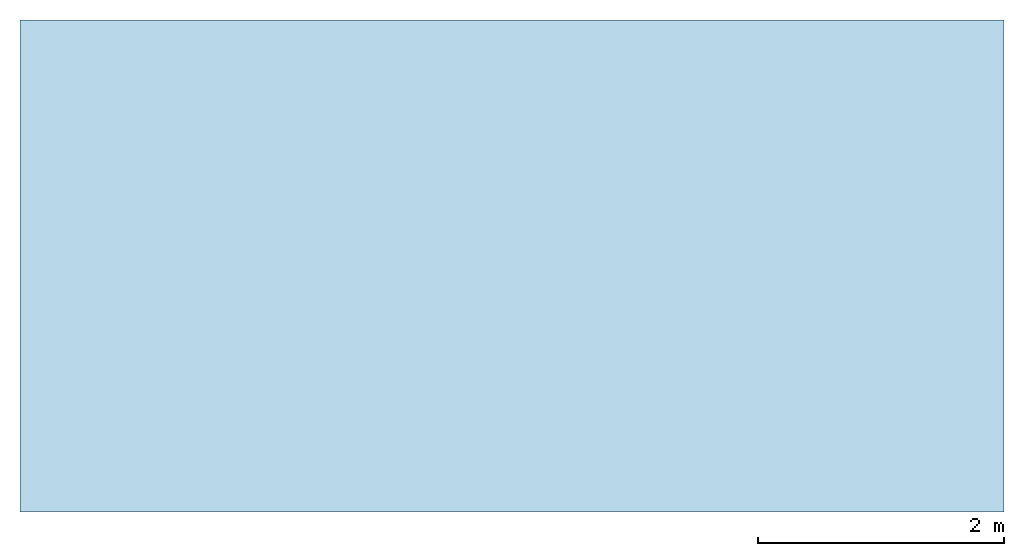
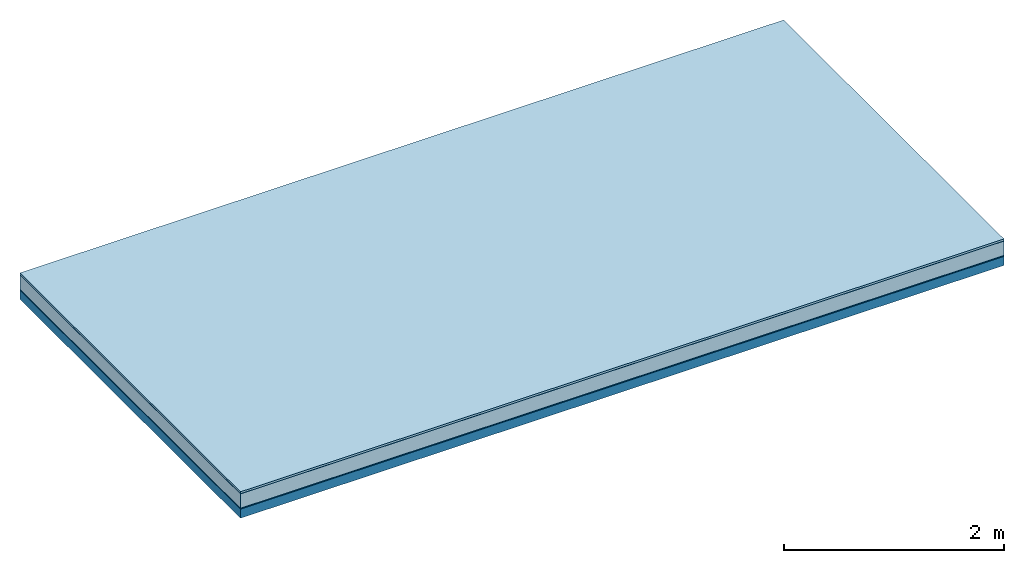
# One storey: 5 plates, 1 member, 1 element without a shape of its own.
"""IFC4 building model written with IfcOpenShell, lengths in metres."""

import ifcopenshell
import ifcopenshell.guid

model = None  # the IFC model being written
_history = None  # IfcOwnerHistory: only IFC2X3 demands one
_inside = {}  # id of a spatial element -> (the spatial element, [elements in it])
_under = {}  # id of a project, library or spatial element -> (it, [spatial elements below it])
_declared = {}  # id of a project -> (the project, [libraries it declares])
_typed = {}  # id of a type object -> (the type object, [elements of that type])
_made_of = {}  # id of a material, layer set ... -> (it, [elements and type objects made of it])


def new_model(schema):
    """Start an empty IFC model of exactly this schema.

    Asked for "IFC4X3", IfcOpenShell would pick the latest addendum, in which some entities
    have other attributes; the version numbers below select the first issue.
    IFC2X3 requires an IfcOwnerHistory on every rooted entity: one is made here for all.
    """
    global model, _history
    if schema == "IFC4X3":
        model = ifcopenshell.file(schema_version=(4, 3, 0, 0))
    else:
        model = ifcopenshell.file(schema=schema)
    _inside.clear()
    _under.clear()
    _declared.clear()
    _typed.clear()
    _made_of.clear()
    _history = None
    if model.schema == "IFC2X3":
        org = make("IfcOrganization", Name="unknown")
        user = make(
            "IfcPersonAndOrganization",
            ThePerson=make("IfcPerson", FamilyName="unknown"),
            TheOrganization=org,
        )
        app = make(
            "IfcApplication",
            ApplicationDeveloper=org,
            Version="unknown",
            ApplicationFullName="unknown",
            ApplicationIdentifier="unknown",
        )
        _history = make(
            "IfcOwnerHistory",
            OwningUser=user,
            OwningApplication=app,
            ChangeAction="ADDED",
            CreationDate=0,
        )
    return model


def make(cls, **values):
    """One entity of the class cls with the attributes given. An attribute that is None is left unset."""
    return model.create_entity(
        cls, **{name: value for name, value in values.items() if value is not None}
    )


def rooted(cls, **values):
    """An entity with a GlobalId (a new one), such as an element, a storey or a relation."""
    return make(cls, GlobalId=ifcopenshell.guid.new(), OwnerHistory=_history, **values)


def si_unit(unit_type, name, prefix=None):
    """IfcSIUnit, for example si_unit("LENGTHUNIT", "METRE", prefix="MILLI")."""
    return make("IfcSIUnit", UnitType=unit_type, Prefix=prefix, Name=name)


def derived_unit(unit_type, elements):
    """IfcDerivedUnit: a product of units, each with its exponent."""
    return make(
        "IfcDerivedUnit",
        Elements=[
            make("IfcDerivedUnitElement", Unit=unit, Exponent=power)
            for unit, power in elements
        ],
        UnitType=unit_type,
    )


def assignment(units):
    """IfcUnitAssignment: the units of a project."""
    return None if units is None else make("IfcUnitAssignment", Units=units)


def point(xyz):
    """IfcCartesianPoint."""
    return None if xyz is None else make("IfcCartesianPoint", Coordinates=xyz)


def direction(xyz):
    """IfcDirection."""
    return None if xyz is None else make("IfcDirection", DirectionRatios=xyz)


def frame(location, z_axis=None, x_axis=None):
    """IfcAxis2Placement3D, a coordinate frame: its origin and axes. An axis left out is left unset."""
    return make(
        "IfcAxis2Placement3D",
        Location=point(location),
        Axis=direction(z_axis),
        RefDirection=direction(x_axis),
    )


def frame_2d(location, x_axis=None):
    """IfcAxis2Placement2D, a coordinate frame in the plane: its origin and x axis."""
    return make(
        "IfcAxis2Placement2D", Location=point(location), RefDirection=direction(x_axis)
    )


def origin():
    """The frame at (0, 0, 0) with its axes left unset."""
    return frame((0.0, 0.0, 0.0))


def origin_with_axes():
    """The frame at (0, 0, 0) with the z axis (0, 0, 1) and the x axis (1, 0, 0) written out."""
    return frame((0.0, 0.0, 0.0), z_axis=(0.0, 0.0, 1.0), x_axis=(1.0, 0.0, 0.0))


def place(relative_to, where):
    """IfcLocalPlacement: puts the frame where relative to a parent placement (None: the world)."""
    return make(
        "IfcLocalPlacement", PlacementRelTo=relative_to, RelativePlacement=where
    )


def context(
    kind, dimensions, precision=None, world=None, true_north=None, identifier=None
):
    """IfcGeometricRepresentationContext, for example the 3D "Model" context."""
    return make(
        "IfcGeometricRepresentationContext",
        ContextIdentifier=identifier,
        ContextType=kind,
        CoordinateSpaceDimension=dimensions,
        Precision=precision,
        WorldCoordinateSystem=world,
        TrueNorth=true_north,
    )


def project(units=None, contexts=None):
    """IfcProject with its units and contexts."""
    return rooted(
        "IfcProject",
        Name="project",
        RepresentationContexts=contexts,
        UnitsInContext=assignment(units),
    )


def spatial(cls, under=None, at=None, **own):
    """A site, building, storey or space (cls), placed at a placement, below another one or the project."""
    s = rooted(cls, ObjectPlacement=at, **own)
    if under is not None:
        _under.setdefault(under.id(), (under, []))[1].append(s)
    return s


def profile(cls, at=None, kind="AREA", **sizes):
    """A parametric profile (cls). Its sizes go by their IFC names, for example OverallWidth=200.0."""
    return make(cls, ProfileType=kind, Position=at, **sizes)


def rectangle(**sizes):
    """IfcRectangleProfileDef."""
    return profile("IfcRectangleProfileDef", **sizes)


def extrude(swept, where, along, depth):
    """IfcExtrudedAreaSolid: the profile swept, set in the frame where, extruded along a direction by depth."""
    return make(
        "IfcExtrudedAreaSolid",
        SweptArea=swept,
        Position=where,
        ExtrudedDirection=direction(along),
        Depth=depth,
    )


def shape(context_of_items, identifier, shape_type, items):
    """IfcShapeRepresentation: the items that make up one representation, for example the "Body"."""
    return make(
        "IfcShapeRepresentation",
        ContextOfItems=context_of_items,
        RepresentationIdentifier=identifier,
        RepresentationType=shape_type,
        Items=items,
    )


def material(Name=None, Category=None):
    """IfcMaterial."""
    return make("IfcMaterial", Name=Name, Category=Category)


def layer(
    of_material, thickness, ventilated=None, Name=None, Category=None, Priority=None
):
    """IfcMaterialLayer: one layer of a wall or slab, of a material (None: an air gap)."""
    return make(
        "IfcMaterialLayer",
        Material=of_material,
        LayerThickness=thickness,
        IsVentilated=ventilated,
        Name=Name,
        Category=Category,
        Priority=Priority,
    )


def layer_set(layers, Name=None):
    """IfcMaterialLayerSet."""
    return make("IfcMaterialLayerSet", MaterialLayers=layers, LayerSetName=Name)


def made_of(thing, what):
    """Note that an element or type object is made of a material, layer set ...; save() writes the relation."""
    if what is not None:
        _made_of.setdefault(what.id(), (what, []))[1].append(thing)
    return thing


def type_object(cls, material=None, **own):
    """A type object (cls), such as IfcWallType, which elements share."""
    return made_of(rooted(cls, **own), material)


def element(
    cls,
    number,
    at=None,
    inside=None,
    cuts=None,
    type_object=None,
    material=None,
    context=None,
    identifier="Body",
    shape_type=None,
    held_by="IfcProductDefinitionShape",
    body=None,
    shapes=None,
    **own,
):
    """One element of the class cls, such as IfcWall. Its Tag is "e" and its number.

    at: its placement. inside: the storey or other place that contains it. cuts: it is an
    opening in that element (IfcRelVoidsElement). A single representation is given by context,
    identifier, shape_type and body (its items); several are given by shapes. held_by: the class
    of the entity that holds the representations. save() writes the other relations.
    """
    e = rooted(cls, Tag="e%d" % number, ObjectPlacement=at, **own)
    if body is not None:
        shapes = [shape(context, identifier, shape_type, body)]
    if shapes is not None:
        e.Representation = make(held_by, Representations=shapes)
    if inside is not None:
        _inside.setdefault(inside.id(), (inside, []))[1].append(e)
    if cuts is not None:
        rooted(
            "IfcRelVoidsElement", RelatingBuildingElement=cuts, RelatedOpeningElement=e
        )
    if type_object is not None:
        _typed.setdefault(type_object.id(), (type_object, []))[1].append(e)
    return made_of(e, material)


def aggregate(whole, parts):
    """IfcRelAggregates: a whole, such as a stair, and the parts it consists of."""
    return rooted("IfcRelAggregates", RelatingObject=whole, RelatedObjects=parts)


def save(model, path):
    """Write the relations noted so far, then the file.

    IfcRelAggregates (storeys below a building ...), IfcRelContainedInSpatialStructure (elements
    in a storey), IfcRelDefinesByType, IfcRelAssociatesMaterial and IfcRelDeclares: one each for
    every whole, place, type object, material and project.
    """
    for whole, parts in _under.values():
        aggregate(whole, parts)
    for where, things in _inside.values():
        rooted(
            "IfcRelContainedInSpatialStructure",
            RelatedElements=things,
            RelatingStructure=where,
        )
    for kind, things in _typed.values():
        rooted("IfcRelDefinesByType", RelatedObjects=things, RelatingType=kind)
    for what, things in _made_of.values():
        rooted("IfcRelAssociatesMaterial", RelatedObjects=things, RelatingMaterial=what)
    for by, libraries in _declared.values():
        rooted("IfcRelDeclares", RelatingContext=by, RelatedDefinitions=libraries)
    model.write(path)


model = new_model("IFC4")

# Units and contexts
plan_context = context("Plan", 3, precision=1e-05, world=origin(), true_north=direction((0.0, 1.0)))
model_context = context("Model", 3, precision=1e-05, world=origin(), true_north=direction((0.0, 1.0)))
ifc_project = project(units=[si_unit("LENGTHUNIT", "METRE"), derived_unit("SOUNDPRESSUREUNIT", [(si_unit("PRESSUREUNIT", "PASCAL", prefix="MICRO"), 0)]), si_unit("ENERGYUNIT", "JOULE", prefix="MEGA"), si_unit("MASSUNIT", "GRAM", prefix="KILO"), derived_unit("THERMALTRANSMITTANCEUNIT", [(si_unit("POWERUNIT", "WATT"), 1), (si_unit("AREAUNIT", "SQUARE_METRE"), -1), (si_unit("THERMODYNAMICTEMPERATUREUNIT", "KELVIN"), -1)]), derived_unit("AREADENSITYUNIT", [(si_unit("MASSUNIT", "GRAM", prefix="KILO"), 1), (si_unit("AREAUNIT", "SQUARE_METRE"), -1)]), derived_unit("USERDEFINED", [(si_unit("ENERGYUNIT", "JOULE", prefix="MEGA"), 1), (si_unit("AREAUNIT", "SQUARE_METRE"), -1)])], contexts=[plan_context, model_context])

# Site, building, storey
site = spatial("IfcSite", under=ifc_project)
building_placement = place(None, origin())
building = spatial("IfcBuilding", under=site, at=building_placement)
storey_placement = place(building_placement, origin())
storey = spatial("IfcBuildingStorey", under=building, at=storey_placement)

# Slab, member, plates
ifc_material_1 = material(Name="with tongue and groove", Category="07.009")
ifc_layer_1 = layer(ifc_material_1, 0.022, Name="Flooring")
ifc_material_2 = material(Category="09.006")
ifc_layer_2 = layer(ifc_material_2, 0.0005, Name="layer")
ifc_material_3 = material(Name="2x 60x80mm")
ifc_layer_3 = layer(ifc_material_3, 0.16, Name="On-material")
ifc_material_4 = material(Name="Wood fiber generic product", Category="10.009")
ifc_layer_4 = layer(ifc_material_4, 0.01, Name="Impact sound insulation")
ifc_material_5 = material(Name="protection", Category="09.007")
ifc_layer_5 = layer(ifc_material_5, 0.0005, Name="Sub-floor")
ifc_material_6 = material(Name="no composite action")
ifc_layer_6 = layer(ifc_material_6, 0.0, Name="Bond")
ifc_layer_7 = layer(None, 0.1, Name="Supporting structure")
ifc_layer_set = layer_set([ifc_layer_1, ifc_layer_2, ifc_layer_3, ifc_layer_4, ifc_layer_5, ifc_layer_6, ifc_layer_7])
slab_type = type_object("IfcSlabType", Name="A2023", PredefinedType="NOTDEFINED", material=ifc_layer_set)
slab_placement = place(None, frame((0.0, 0.0, 0.0), z_axis=(0.0, 0.0, -1.0), x_axis=(1.0, 0.0, 0.0)))
slab = element("IfcSlab", 1, at=slab_placement, inside=storey, type_object=slab_type, material=ifc_layer_set, Name="Slab #1")
ifc_material_7 = material(Name="Solid timber panel")
member_placement = place(slab_placement, origin())
member = element("IfcMember", 2, at=member_placement, material=ifc_material_7, Name="Supporting structure", context=plan_context, shape_type="SweptSolid", body=[
    extrude(rectangle(XDim=1.0, YDim=0.1, at=frame_2d((0.5, 0.05), x_axis=(1.0, 0.0))), frame((0.0, 4.0, 0.193), z_axis=(0.0, -1.0, 0.0), x_axis=(1.0, 0.0, 0.0)), (0.0, 0.0, 1.0), 4.0),
    extrude(rectangle(XDim=1.0, YDim=0.1, at=frame_2d((0.5, 0.05), x_axis=(1.0, 0.0))), frame((1.0, 4.0, 0.193), z_axis=(0.0, -1.0, 0.0), x_axis=(1.0, 0.0, 0.0)), (0.0, 0.0, 1.0), 4.0),
    extrude(rectangle(XDim=1.0, YDim=0.1, at=frame_2d((0.5, 0.05), x_axis=(1.0, 0.0))), frame((2.0, 4.0, 0.193), z_axis=(0.0, -1.0, 0.0), x_axis=(1.0, 0.0, 0.0)), (0.0, 0.0, 1.0), 4.0),
    extrude(rectangle(XDim=1.0, YDim=0.1, at=frame_2d((0.5, 0.05), x_axis=(1.0, 0.0))), frame((3.0, 4.0, 0.193), z_axis=(0.0, -1.0, 0.0), x_axis=(1.0, 0.0, 0.0)), (0.0, 0.0, 1.0), 4.0),
    extrude(rectangle(XDim=1.0, YDim=0.1, at=frame_2d((0.5, 0.05), x_axis=(1.0, 0.0))), frame((4.0, 4.0, 0.193), z_axis=(0.0, -1.0, 0.0), x_axis=(1.0, 0.0, 0.0)), (0.0, 0.0, 1.0), 4.0),
    extrude(rectangle(XDim=1.0, YDim=0.1, at=frame_2d((0.5, 0.05), x_axis=(1.0, 0.0))), frame((5.0, 4.0, 0.193), z_axis=(0.0, -1.0, 0.0), x_axis=(1.0, 0.0, 0.0)), (0.0, 0.0, 1.0), 4.0),
    extrude(rectangle(XDim=1.0, YDim=0.1, at=frame_2d((0.5, 0.05), x_axis=(1.0, 0.0))), frame((6.0, 4.0, 0.193), z_axis=(0.0, -1.0, 0.0), x_axis=(1.0, 0.0, 0.0)), (0.0, 0.0, 1.0), 4.0),
    extrude(rectangle(XDim=1.0, YDim=0.1, at=frame_2d((0.5, 0.05), x_axis=(1.0, 0.0))), frame((7.0, 4.0, 0.193), z_axis=(0.0, -1.0, 0.0), x_axis=(1.0, 0.0, 0.0)), (0.0, 0.0, 1.0), 4.0),
])
plate_1_placement = place(slab_placement, origin())
plate_1 = element("IfcPlate", 3, at=plate_1_placement, material=ifc_material_1, Name="Flooring", context=plan_context, shape_type="SweptSolid", body=[
    extrude(rectangle(XDim=8.0, YDim=4.0, at=frame_2d((4.0, 2.0), x_axis=(1.0, 0.0))), origin_with_axes(), (0.0, 0.0, 1.0), 0.022),
])
plate_2_placement = place(slab_placement, origin())
plate_2 = element("IfcPlate", 4, at=plate_2_placement, material=ifc_material_2, Name="layer", context=plan_context, shape_type="SweptSolid", body=[
    extrude(rectangle(XDim=8.0, YDim=4.0, at=frame_2d((4.0, 2.0), x_axis=(1.0, 0.0))), frame((0.0, 0.0, 0.022), z_axis=(0.0, 0.0, 1.0), x_axis=(1.0, 0.0, 0.0)), (0.0, 0.0, 1.0), 0.0005),
])
plate_3_placement = place(slab_placement, origin())
plate_3 = element("IfcPlate", 5, at=plate_3_placement, material=ifc_material_3, Name="On-material", context=plan_context, shape_type="SweptSolid", body=[
    extrude(rectangle(XDim=8.0, YDim=4.0, at=frame_2d((4.0, 2.0), x_axis=(1.0, 0.0))), frame((0.0, 0.0, 0.0225), z_axis=(0.0, 0.0, 1.0), x_axis=(1.0, 0.0, 0.0)), (0.0, 0.0, 1.0), 0.16),
])
plate_4_placement = place(slab_placement, origin())
plate_4 = element("IfcPlate", 6, at=plate_4_placement, material=ifc_material_4, Name="Impact sound insulation", context=plan_context, shape_type="SweptSolid", body=[
    extrude(rectangle(XDim=8.0, YDim=4.0, at=frame_2d((4.0, 2.0), x_axis=(1.0, 0.0))), frame((0.0, 0.0, 0.1825), z_axis=(0.0, 0.0, 1.0), x_axis=(1.0, 0.0, 0.0)), (0.0, 0.0, 1.0), 0.01),
])
plate_5_placement = place(slab_placement, origin())
plate_5 = element("IfcPlate", 7, at=plate_5_placement, material=ifc_material_5, Name="Sub-floor", context=plan_context, shape_type="SweptSolid", body=[
    extrude(rectangle(XDim=8.0, YDim=4.0, at=frame_2d((4.0, 2.0), x_axis=(1.0, 0.0))), frame((0.0, 0.0, 0.1925), z_axis=(0.0, 0.0, 1.0), x_axis=(1.0, 0.0, 0.0)), (0.0, 0.0, 1.0), 0.0005),
])
aggregate(slab, [plate_1, plate_2, plate_3, plate_4, plate_5, member])

save(model, "model.ifc")
